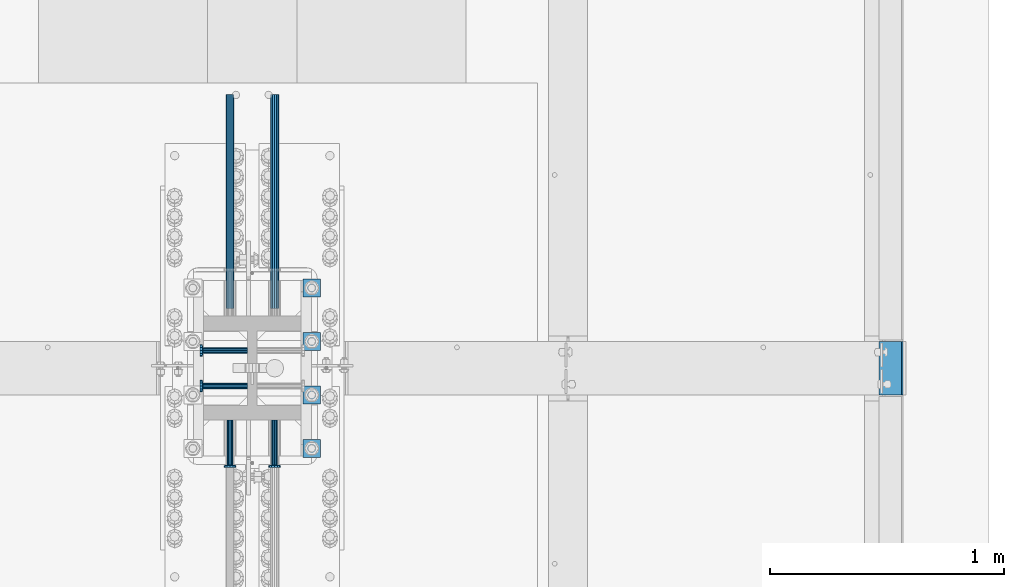
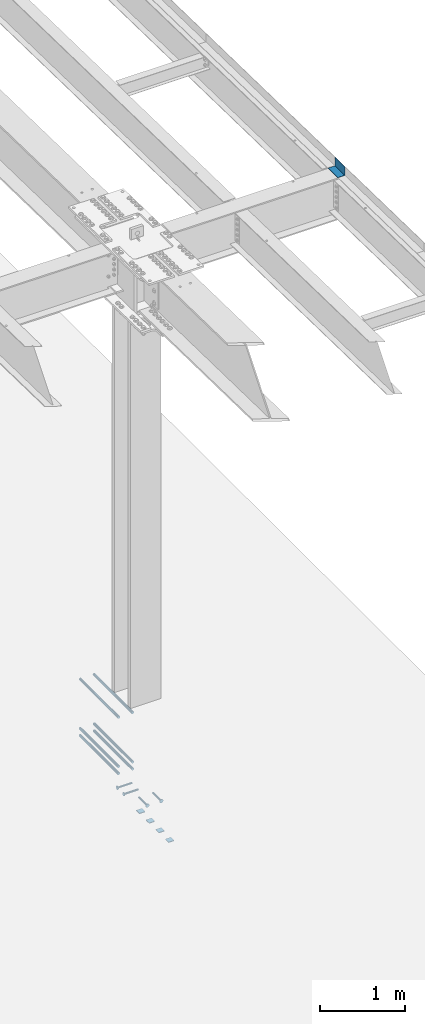
# One storey, part 1312 of 1763: 15 beams, 9 elements without a shape of their own.
"""IFC2X3 building model written with IfcOpenShell, lengths in millimetres."""

from ifc_helpers import new_model, si_unit, frame, origin_with_axes, place, context, subcontext, project, spatial, faceted_brep, material, type_object, element, aggregate, save


model = new_model("IFC2X3")

# Units and contexts
model_context = context("Model", 3, precision=1e-05, world=origin_with_axes())
body_context = subcontext(model_context, "Body", "Model", "MODEL_VIEW")
ifc_project = project(units=[si_unit("LENGTHUNIT", "METRE", prefix="MILLI"), si_unit("AREAUNIT", "SQUARE_METRE"), si_unit("VOLUMEUNIT", "CUBIC_METRE"), si_unit("MASSUNIT", "GRAM", prefix="KILO"), si_unit("TIMEUNIT", "SECOND"), si_unit("PLANEANGLEUNIT", "RADIAN"), si_unit("SOLIDANGLEUNIT", "STERADIAN"), si_unit("THERMODYNAMICTEMPERATUREUNIT", "DEGREE_CELSIUS"), si_unit("LUMINOUSINTENSITYUNIT", "LUMEN")], contexts=[model_context])

# Site, building, storey
site_placement = place(None, origin_with_axes())
site = spatial("IfcSite", under=ifc_project, at=site_placement, CompositionType="ELEMENT")
building_placement = place(site_placement, origin_with_axes())
building = spatial("IfcBuilding", under=site, at=building_placement, Name="Undefined", CompositionType="ELEMENT")
storey_placement = place(building_placement, origin_with_axes())
storey = spatial("IfcBuildingStorey", under=building, at=storey_placement, Name="Undefined", CompositionType="ELEMENT", Elevation=0.0)

# Assembly, beam
assembly_1_placement = place(storey_placement, origin_with_axes())
assembly_1 = element("IfcElementAssembly", 1, at=assembly_1_placement, inside=storey, Name="BEAM", AssemblyPlace="NOTDEFINED", PredefinedType="RIGID_FRAME")
ifc_material_1 = material(Name="STEEL/A36")
beam_type_1 = type_object("IfcBeamType", PredefinedType="NOTDEFINED")
beam_1_placement = place(assembly_1_placement, frame((-21348.1372736974, 457.200000000003, 11911.5711714953), z_axis=(0.0, -1.0, 0.0), x_axis=(1.0, 0.0, 0.0)))
beam_1 = element("IfcBeam", 2, at=beam_1_placement, type_object=beam_type_1, material=ifc_material_1, Name="BENT_PLATE", context=body_context, shape_type="Brep", body=[
    faceted_brep([(0.0, -3.17499999999927, -114.300000000003), (0.0, -3.17499999999927, 114.300000000003), (0.0, 3.17499999999927, 114.300000000003), (0.0, 3.17499999999927, -114.300000000003), (95.2499984741225, 3.17499999999927, 114.299999999999), (95.2499984741225, 3.17499999999927, -114.299999999999), (101.599998474121, -3.17499999999927, -114.299999999999), (101.599998474121, -3.17499999999927, 114.299999999999), (95.2499984741225, 123.825000000001, 114.299999999999), (95.2499984741225, 123.825000000001, -114.299999999999), (101.599998474121, 123.825000000001, 114.299999999999), (101.599998474121, 123.825000000001, -114.299999999999)], [[[0, 1, 2, 3]], [[3, 2, 4, 5]], [[1, 0, 6, 7]], [[5, 4, 8, 9]], [[4, 2, 1, 7, 10, 8]], [[7, 6, 11, 10]], [[6, 0, 3, 5, 9, 11]], [[10, 11, 9, 8]]]),
])
aggregate(assembly_1, [beam_1])

# Assembly, beams
assembly_2_placement = place(storey_placement, origin_with_axes())
assembly_2 = element("IfcElementAssembly", 3, at=assembly_2_placement, inside=storey, Name="TEMPLATE", AssemblyPlace="NOTDEFINED", PredefinedType="RIGID_FRAME")
beam_type_2 = type_object("IfcBeamType", PredefinedType="NOTDEFINED")
beam_2_placement = place(assembly_2_placement, frame((-23773.8372736984, 76.1999999999981, 3348.0375), z_axis=(1.0, 0.0, 0.0), x_axis=(0.0, 1.0, 0.0)))
beam_2 = element("IfcBeam", 4, at=beam_2_placement, type_object=beam_type_2, material=ifc_material_1, Name="WASHER PLATE", context=body_context, shape_type="Brep", body=[
    faceted_brep([(0.0, 4.76249999999709, -38.1000000000004), (0.0, 4.76249999999709, 38.1000000000004), (76.2000000000007, 4.76249999999982, 38.0999999999985), (76.2000000000007, 4.76249999999982, -38.0999999999985), (0.0, -4.76249999999709, 38.1000000000004), (76.2000000000007, -4.76249999999982, 38.0999999999985), (0.0, -4.76249999999709, -38.1000000000004), (76.2000000000007, -4.76249999999982, -38.0999999999985)], [[[0, 1, 2, 3]], [[1, 4, 5, 2]], [[4, 6, 7, 5]], [[6, 0, 3, 7]], [[5, 7, 3, 2]], [[6, 4, 1, 0]]]),
])
beam_3_placement = place(assembly_2_placement, frame((-23773.8372736984, 304.799999999998, 3348.0375), z_axis=(1.0, 0.0, 0.0), x_axis=(0.0, 1.0, 0.0)))
beam_3 = element("IfcBeam", 5, at=beam_3_placement, type_object=beam_type_2, material=ifc_material_1, Name="WASHER PLATE", context=body_context, shape_type="Brep", body=[
    faceted_brep([(0.0, 4.76249999999709, -38.1000000000004), (0.0, 4.76249999999709, 38.1000000000004), (76.2000000000007, 4.76249999999982, 38.0999999999985), (76.2000000000007, 4.76249999999982, -38.0999999999985), (0.0, -4.76249999999709, 38.1000000000004), (76.2000000000007, -4.76249999999982, 38.0999999999985), (0.0, -4.76249999999709, -38.1000000000004), (76.2000000000007, -4.76249999999982, -38.0999999999985)], [[[0, 1, 2, 3]], [[1, 4, 5, 2]], [[4, 6, 7, 5]], [[6, 0, 3, 7]], [[5, 7, 3, 2]], [[6, 4, 1, 0]]]),
])
beam_4_placement = place(assembly_2_placement, frame((-23773.8372736984, 533.399999999998, 3348.0375), z_axis=(1.0, 0.0, 0.0), x_axis=(0.0, 1.0, 0.0)))
beam_4 = element("IfcBeam", 6, at=beam_4_placement, type_object=beam_type_2, material=ifc_material_1, Name="WASHER PLATE", context=body_context, shape_type="Brep", body=[
    faceted_brep([(0.0, 4.76249999999709, -38.1000000000004), (0.0, 4.76249999999709, 38.1000000000004), (76.2000000000007, 4.76249999999982, 38.0999999999985), (76.2000000000007, 4.76249999999982, -38.0999999999985), (0.0, -4.76249999999709, 38.1000000000004), (76.2000000000007, -4.76249999999982, 38.0999999999985), (0.0, -4.76249999999709, -38.1000000000004), (76.2000000000007, -4.76249999999982, -38.0999999999985)], [[[0, 1, 2, 3]], [[1, 4, 5, 2]], [[4, 6, 7, 5]], [[6, 0, 3, 7]], [[5, 7, 3, 2]], [[6, 4, 1, 0]]]),
])
beam_5_placement = place(assembly_2_placement, frame((-23773.8372736984, 761.999999999998, 3348.0375), z_axis=(1.0, 0.0, 0.0), x_axis=(0.0, 1.0, 0.0)))
beam_5 = element("IfcBeam", 7, at=beam_5_placement, type_object=beam_type_2, material=ifc_material_1, Name="WASHER PLATE", context=body_context, shape_type="Brep", body=[
    faceted_brep([(0.0, 4.76249999999709, -38.1000000000004), (0.0, 4.76249999999709, 38.1000000000004), (76.2000000000007, 4.76249999999982, 38.0999999999985), (76.2000000000007, 4.76249999999982, -38.0999999999985), (0.0, -4.76249999999709, 38.1000000000004), (76.2000000000007, -4.76249999999982, 38.0999999999985), (0.0, -4.76249999999709, -38.1000000000004), (76.2000000000007, -4.76249999999982, -38.0999999999985)], [[[0, 1, 2, 3]], [[1, 4, 5, 2]], [[4, 6, 7, 5]], [[6, 0, 3, 7]], [[5, 7, 3, 2]], [[6, 4, 1, 0]]]),
])
aggregate(assembly_2, [beam_2, beam_3, beam_4, beam_5])

# Assembly, beam
assembly_3_placement = place(storey_placement, origin_with_axes())
assembly_3 = element("IfcElementAssembly", 8, at=assembly_3_placement, inside=storey, Name="REBAR", AssemblyPlace="NOTDEFINED", PredefinedType="RIGID_FRAME")
ifc_material_2 = material(Name="STEEL/A706-GR.80")
beam_type_3 = type_object("IfcBeamType", Name="#11 REBAR", PredefinedType="NOTDEFINED")
beam_6_placement = place(assembly_3_placement, frame((-23932.5872736985, 712.215793794025, 4165.6), z_axis=(0.0, 0.0, 1.0), x_axis=(0.0, 1.0, 0.0)))
beam_6 = element("IfcBeam", 9, at=beam_6_placement, type_object=beam_type_3, material=ifc_material_2, Name="REBAR", ObjectType="#11 REBAR", context=body_context, shape_type="Brep", body=[
    faceted_brep([(0.0, -17.9069999999992, 0.0), (0.0, -15.507916905568, -8.95349999999962), (914.400000001086, -15.507916905568, -8.95349999999962), (914.400000001086, -17.9069999999992, 0.0), (0.0, -8.95349999999962, -15.507916905568), (914.400000001086, -8.95349999999962, -15.507916905568), (0.0, 0.0, -17.9070000000002), (914.400000001086, 0.0, -17.9070000000002), (0.0, 8.95349999999962, -15.507916905568), (914.400000001086, 8.95349999999962, -15.507916905568), (0.0, 15.507916905568, -8.95349999999962), (914.400000001086, 15.507916905568, -8.95349999999962), (0.0, 17.9069999999992, 0.0), (914.400000001086, 17.9069999999992, 0.0), (0.0, 15.507916905568, 8.95349999999962), (914.400000001086, 15.507916905568, 8.95349999999962), (0.0, 8.95349999999962, 15.507916905568), (914.400000001086, 8.95349999999962, 15.507916905568), (0.0, 0.0, 17.9070000000002), (914.400000001086, 0.0, 17.9070000000002), (0.0, -8.95349999999962, 15.507916905568), (914.400000001086, -8.95349999999962, 15.507916905568), (0.0, -15.507916905568, 8.95349999999962), (914.400000001086, -15.507916905568, 8.95349999999962)], [[[0, 1, 2, 3]], [[1, 4, 5, 2]], [[4, 6, 7, 5]], [[6, 8, 9, 7]], [[8, 10, 11, 9]], [[10, 12, 13, 11]], [[12, 14, 15, 13]], [[14, 16, 17, 15]], [[16, 18, 19, 17]], [[18, 20, 21, 19]], [[20, 22, 23, 21]], [[22, 0, 3, 23]], [[5, 7, 9, 11, 13, 15, 17, 19, 21, 23, 3, 2]], [[22, 20, 18, 16, 14, 12, 10, 8, 6, 4, 1, 0]]]),
])
aggregate(assembly_3, [beam_6])

assembly_4_placement = place(storey_placement, origin_with_axes())
assembly_4 = element("IfcElementAssembly", 10, at=assembly_4_placement, inside=storey, Name="REBAR", AssemblyPlace="NOTDEFINED", PredefinedType="RIGID_FRAME")
beam_7_placement = place(assembly_4_placement, frame((-24123.0872736984, 712.215862529549, 4165.6), z_axis=(0.0, 0.0, 1.0), x_axis=(0.0, 1.0, 0.0)))
beam_7 = element("IfcBeam", 11, at=beam_7_placement, type_object=beam_type_3, material=ifc_material_2, Name="REBAR", ObjectType="#11 REBAR", context=body_context, shape_type="Brep", body=[
    faceted_brep([(0.0, -17.9069999999992, 0.0), (0.0, -15.507916905568, -8.95349999999962), (914.400000001086, -15.507916905568, -8.95349999999962), (914.400000001086, -17.9069999999992, 0.0), (0.0, -8.95349999999962, -15.507916905568), (914.400000001086, -8.95349999999962, -15.507916905568), (0.0, 0.0, -17.9070000000002), (914.400000001086, 0.0, -17.9070000000002), (0.0, 8.95349999999962, -15.507916905568), (914.400000001086, 8.95349999999962, -15.507916905568), (0.0, 15.507916905568, -8.95349999999962), (914.400000001086, 15.507916905568, -8.95349999999962), (0.0, 17.9069999999992, 0.0), (914.400000001086, 17.9069999999992, 0.0), (0.0, 15.507916905568, 8.95349999999962), (914.400000001086, 15.507916905568, 8.95349999999962), (0.0, 8.95349999999962, 15.507916905568), (914.400000001086, 8.95349999999962, 15.507916905568), (0.0, 0.0, 17.9070000000002), (914.400000001086, 0.0, 17.9070000000002), (0.0, -8.95349999999962, 15.507916905568), (914.400000001086, -8.95349999999962, 15.507916905568), (0.0, -15.507916905568, 8.95349999999962), (914.400000001086, -15.507916905568, 8.95349999999962)], [[[0, 1, 2, 3]], [[1, 4, 5, 2]], [[4, 6, 7, 5]], [[6, 8, 9, 7]], [[8, 10, 11, 9]], [[10, 12, 13, 11]], [[12, 14, 15, 13]], [[14, 16, 17, 15]], [[16, 18, 19, 17]], [[18, 20, 21, 19]], [[20, 22, 23, 21]], [[22, 0, 3, 23]], [[5, 7, 9, 11, 13, 15, 17, 19, 21, 23, 3, 2]], [[22, 20, 18, 16, 14, 12, 10, 8, 6, 4, 1, 0]]]),
])
aggregate(assembly_4, [beam_7])

assembly_5_placement = place(storey_placement, origin_with_axes())
assembly_5 = element("IfcElementAssembly", 12, at=assembly_5_placement, inside=storey, Name="REBAR", AssemblyPlace="NOTDEFINED", PredefinedType="RIGID_FRAME")
beam_8_placement = place(assembly_5_placement, frame((-23932.5872736985, 712.215793794024, 4064.0), z_axis=(0.0, 0.0, 1.0), x_axis=(0.0, 1.0, 0.0)))
beam_8 = element("IfcBeam", 13, at=beam_8_placement, type_object=beam_type_3, material=ifc_material_2, Name="REBAR", ObjectType="#11 REBAR", context=body_context, shape_type="Brep", body=[
    faceted_brep([(0.0, -17.9069999999992, 0.0), (0.0, -15.507916905568, -8.95349999999962), (914.400000001086, -15.507916905568, -8.95349999999962), (914.400000001086, -17.9069999999992, 0.0), (0.0, -8.95349999999962, -15.507916905568), (914.400000001086, -8.95349999999962, -15.507916905568), (0.0, 0.0, -17.9070000000002), (914.400000001086, 0.0, -17.9070000000002), (0.0, 8.95349999999962, -15.507916905568), (914.400000001086, 8.95349999999962, -15.507916905568), (0.0, 15.507916905568, -8.95349999999962), (914.400000001086, 15.507916905568, -8.95349999999962), (0.0, 17.9069999999992, 0.0), (914.400000001086, 17.9069999999992, 0.0), (0.0, 15.507916905568, 8.95349999999962), (914.400000001086, 15.507916905568, 8.95349999999962), (0.0, 8.95349999999962, 15.507916905568), (914.400000001086, 8.95349999999962, 15.507916905568), (0.0, 0.0, 17.9070000000002), (914.400000001086, 0.0, 17.9070000000002), (0.0, -8.95349999999962, 15.507916905568), (914.400000001086, -8.95349999999962, 15.507916905568), (0.0, -15.507916905568, 8.95349999999962), (914.400000001086, -15.507916905568, 8.95349999999962)], [[[0, 1, 2, 3]], [[1, 4, 5, 2]], [[4, 6, 7, 5]], [[6, 8, 9, 7]], [[8, 10, 11, 9]], [[10, 12, 13, 11]], [[12, 14, 15, 13]], [[14, 16, 17, 15]], [[16, 18, 19, 17]], [[18, 20, 21, 19]], [[20, 22, 23, 21]], [[22, 0, 3, 23]], [[5, 7, 9, 11, 13, 15, 17, 19, 21, 23, 3, 2]], [[22, 20, 18, 16, 14, 12, 10, 8, 6, 4, 1, 0]]]),
])
aggregate(assembly_5, [beam_8])

assembly_6_placement = place(storey_placement, origin_with_axes())
assembly_6 = element("IfcElementAssembly", 14, at=assembly_6_placement, inside=storey, Name="REBAR", AssemblyPlace="NOTDEFINED", PredefinedType="RIGID_FRAME")
beam_9_placement = place(assembly_6_placement, frame((-24123.0872736984, 712.215862529548, 4064.0), z_axis=(0.0, 0.0, 1.0), x_axis=(0.0, 1.0, 0.0)))
beam_9 = element("IfcBeam", 15, at=beam_9_placement, type_object=beam_type_3, material=ifc_material_2, Name="REBAR", ObjectType="#11 REBAR", context=body_context, shape_type="Brep", body=[
    faceted_brep([(0.0, -17.9069999999992, 0.0), (0.0, -15.507916905568, -8.95349999999962), (914.400000001086, -15.507916905568, -8.95349999999962), (914.400000001086, -17.9069999999992, 0.0), (0.0, -8.95349999999962, -15.507916905568), (914.400000001086, -8.95349999999962, -15.507916905568), (0.0, 0.0, -17.9070000000002), (914.400000001086, 0.0, -17.9070000000002), (0.0, 8.95349999999962, -15.507916905568), (914.400000001086, 8.95349999999962, -15.507916905568), (0.0, 15.507916905568, -8.95349999999962), (914.400000001086, 15.507916905568, -8.95349999999962), (0.0, 17.9069999999992, 0.0), (914.400000001086, 17.9069999999992, 0.0), (0.0, 15.507916905568, 8.95349999999962), (914.400000001086, 15.507916905568, 8.95349999999962), (0.0, 8.95349999999962, 15.507916905568), (914.400000001086, 8.95349999999962, 15.507916905568), (0.0, 0.0, 17.9070000000002), (914.400000001086, 0.0, 17.9070000000002), (0.0, -8.95349999999962, 15.507916905568), (914.400000001086, -8.95349999999962, 15.507916905568), (0.0, -15.507916905568, 8.95349999999962), (914.400000001086, -15.507916905568, 8.95349999999962)], [[[0, 1, 2, 3]], [[1, 4, 5, 2]], [[4, 6, 7, 5]], [[6, 8, 9, 7]], [[8, 10, 11, 9]], [[10, 12, 13, 11]], [[12, 14, 15, 13]], [[14, 16, 17, 15]], [[16, 18, 19, 17]], [[18, 20, 21, 19]], [[20, 22, 23, 21]], [[22, 0, 3, 23]], [[5, 7, 9, 11, 13, 15, 17, 19, 21, 23, 3, 2]], [[22, 20, 18, 16, 14, 12, 10, 8, 6, 4, 1, 0]]]),
])
aggregate(assembly_6, [beam_9])

assembly_7_placement = place(storey_placement, origin_with_axes())
assembly_7 = element("IfcElementAssembly", 16, at=assembly_7_placement, inside=storey, Name="REBAR", AssemblyPlace="NOTDEFINED", PredefinedType="RIGID_FRAME")
beam_10_placement = place(assembly_7_placement, frame((-23932.5872736985, 712.215931264474, 4876.80000000009), z_axis=(0.0, 0.0, 1.0), x_axis=(0.0, 1.0, 0.0)))
beam_10 = element("IfcBeam", 17, at=beam_10_placement, type_object=beam_type_3, material=ifc_material_2, Name="REBAR", ObjectType="#11 REBAR", context=body_context, shape_type="Brep", body=[
    faceted_brep([(0.0, -17.9069999999992, 0.0), (0.0, -15.507916905568, -8.95349999999962), (914.400000001086, -15.507916905568, -8.95349999999962), (914.400000001086, -17.9069999999992, 0.0), (0.0, -8.95349999999962, -15.507916905568), (914.400000001086, -8.95349999999962, -15.507916905568), (0.0, 0.0, -17.9070000000002), (914.400000001086, 0.0, -17.9070000000002), (0.0, 8.95349999999962, -15.507916905568), (914.400000001086, 8.95349999999962, -15.507916905568), (0.0, 15.507916905568, -8.95349999999962), (914.400000001086, 15.507916905568, -8.95349999999962), (0.0, 17.9069999999992, 0.0), (914.400000001086, 17.9069999999992, 0.0), (0.0, 15.507916905568, 8.95349999999962), (914.400000001086, 15.507916905568, 8.95349999999962), (0.0, 8.95349999999962, 15.507916905568), (914.400000001086, 8.95349999999962, 15.507916905568), (0.0, 0.0, 17.9070000000002), (914.400000001086, 0.0, 17.9070000000002), (0.0, -8.95349999999962, 15.507916905568), (914.400000001086, -8.95349999999962, 15.507916905568), (0.0, -15.507916905568, 8.95349999999962), (914.400000001086, -15.507916905568, 8.95349999999962)], [[[0, 1, 2, 3]], [[1, 4, 5, 2]], [[4, 6, 7, 5]], [[6, 8, 9, 7]], [[8, 10, 11, 9]], [[10, 12, 13, 11]], [[12, 14, 15, 13]], [[14, 16, 17, 15]], [[16, 18, 19, 17]], [[18, 20, 21, 19]], [[20, 22, 23, 21]], [[22, 0, 3, 23]], [[5, 7, 9, 11, 13, 15, 17, 19, 21, 23, 3, 2]], [[22, 20, 18, 16, 14, 12, 10, 8, 6, 4, 1, 0]]]),
])
aggregate(assembly_7, [beam_10])

assembly_8_placement = place(storey_placement, origin_with_axes())
assembly_8 = element("IfcElementAssembly", 18, at=assembly_8_placement, inside=storey, Name="REBAR", AssemblyPlace="NOTDEFINED", PredefinedType="RIGID_FRAME")
beam_11_placement = place(assembly_8_placement, frame((-24123.0872736984, 712.215999999998, 4876.80000000009), z_axis=(0.0, 0.0, 1.0), x_axis=(0.0, 1.0, 0.0)))
beam_11 = element("IfcBeam", 19, at=beam_11_placement, type_object=beam_type_3, material=ifc_material_2, Name="REBAR", ObjectType="#11 REBAR", context=body_context, shape_type="Brep", body=[
    faceted_brep([(0.0, -17.9069999999992, 0.0), (0.0, -15.507916905568, -8.95349999999962), (914.400000001086, -15.507916905568, -8.95349999999962), (914.400000001086, -17.9069999999992, 0.0), (0.0, -8.95349999999962, -15.507916905568), (914.400000001086, -8.95349999999962, -15.507916905568), (0.0, 0.0, -17.9070000000002), (914.400000001086, 0.0, -17.9070000000002), (0.0, 8.95349999999962, -15.507916905568), (914.400000001086, 8.95349999999962, -15.507916905568), (0.0, 15.507916905568, -8.95349999999962), (914.400000001086, 15.507916905568, -8.95349999999962), (0.0, 17.9069999999992, 0.0), (914.400000001086, 17.9069999999992, 0.0), (0.0, 15.507916905568, 8.95349999999962), (914.400000001086, 15.507916905568, 8.95349999999962), (0.0, 8.95349999999962, 15.507916905568), (914.400000001086, 8.95349999999962, 15.507916905568), (0.0, 0.0, 17.9070000000002), (914.400000001086, 0.0, 17.9070000000002), (0.0, -8.95349999999962, 15.507916905568), (914.400000001086, -8.95349999999962, 15.507916905568), (0.0, -15.507916905568, 8.95349999999962), (914.400000001086, -15.507916905568, 8.95349999999962)], [[[0, 1, 2, 3]], [[1, 4, 5, 2]], [[4, 6, 7, 5]], [[6, 8, 9, 7]], [[8, 10, 11, 9]], [[10, 12, 13, 11]], [[12, 14, 15, 13]], [[14, 16, 17, 15]], [[16, 18, 19, 17]], [[18, 20, 21, 19]], [[20, 22, 23, 21]], [[22, 0, 3, 23]], [[5, 7, 9, 11, 13, 15, 17, 19, 21, 23, 3, 2]], [[22, 20, 18, 16, 14, 12, 10, 8, 6, 4, 1, 0]]]),
])
aggregate(assembly_8, [beam_11])

# Assembly, beams
assembly_9_placement = place(storey_placement, origin_with_axes())
assembly_9 = element("IfcElementAssembly", 20, at=assembly_9_placement, inside=storey, Name="COLUMN", AssemblyPlace="NOTDEFINED", PredefinedType="RIGID_FRAME")
ifc_material_3 = material(Name="STEEL/A108")
beam_type_4 = type_object("IfcBeamType", PredefinedType="NOTDEFINED")
beam_12_placement = place(assembly_9_placement, frame((-24047.6810236984, 533.399999658004, 4013.2), z_axis=(0.0, -1.0, 0.0), x_axis=(-1.0, 0.0, 0.0)))
beam_12 = element("IfcBeam", 21, at=beam_12_placement, type_object=beam_type_4, material=ifc_material_3, Name="HEADED STUD ANCHOR", context=body_context, shape_type="Brep", body=[
    faceted_brep([(0.0, -12.6999999999971, -1.81898940354586e-12), (3.63797880709171e-12, -11.0, -6.34999990463257), (191.00799999576, -11.0, -6.34999990454889), (191.007999995752, -12.6999998092651, 8.36735125631094e-11), (7.27595761418343e-12, -6.34999990463257, -11.0), (191.00799999576, -6.34999990463257, -10.9999999999163), (3.63797880709171e-12, 0.0, -12.6999998092651), (191.00799999576, 0.0, -12.6999998091815), (7.27595761418343e-12, 6.34999990463257, -11.0), (191.00799999576, 6.34999990463257, -10.9999999999163), (3.63797880709171e-12, 11.0, -6.34999990463257), (191.00799999576, 11.0, -6.34999990454889), (0.0, 12.6999999999971, -1.81898940354586e-12), (191.007999995752, 12.6999998092651, 8.36735125631094e-11), (0.0, 11.0, 6.34999990463257), (191.007999995752, 11.0, 6.34999990471624), (-3.63797880709171e-12, 6.34999990463257, 11.0), (191.007999995749, 6.34999990463257, 11.0000000000837), (-3.63797880709171e-12, 0.0, 12.6999998092651), (191.007999995749, 0.0, 12.6999998093488), (-3.63797880709171e-12, -6.34999990463257, 11.0), (191.007999995749, -6.34999990463257, 11.0000000000837), (0.0, -11.0, 6.34999990463257), (191.007999995752, -11.0, 6.34999990471624), (193.039999995715, -22.0, -12.6999998091796), (193.039999995708, -25.3999996185303, 8.54925019666553e-11), (193.039999995719, -12.6999998092651, -21.9999999999145), (193.039999995719, 0.0, -25.3999996184448), (193.039999995719, 12.6999998092651, -21.9999999999145), (193.039999995715, 22.0, -12.6999998091796), (193.039999995708, 25.3999996185303, 8.54925019666553e-11), (193.039999995704, 22.0, 12.6999998093506), (193.039999995701, 12.6999998092651, 22.0000000000855), (193.039999995697, 0.0, 25.3999996186158), (193.039999995701, -12.6999998092651, 22.0000000000855), (193.039999995704, -22.0, 12.6999998093506), (203.199999995486, -22.0, -12.6999998091742), (203.199999995482, -25.3999996185303, 9.09494701772928e-11), (203.199999995493, -12.6999998092651, -21.9999999999091), (203.199999995493, 0.0, -25.3999996184393), (203.199999995493, 12.6999998092651, -21.9999999999091), (203.199999995486, 22.0, -12.6999998091742), (203.199999995482, 25.3999996185303, 9.09494701772928e-11), (203.199999995479, 22.0, 12.6999998093561), (203.199999995475, 12.6999998092651, 22.0000000000909), (203.199999995471, 0.0, 25.3999996186212), (203.199999995475, -12.6999998092651, 22.0000000000909), (203.199999995479, -22.0, 12.6999998093561)], [[[0, 1, 2, 3]], [[1, 4, 5, 2]], [[4, 6, 7, 5]], [[6, 8, 9, 7]], [[8, 10, 11, 9]], [[10, 12, 13, 11]], [[12, 14, 15, 13]], [[14, 16, 17, 15]], [[16, 18, 19, 17]], [[18, 20, 21, 19]], [[20, 22, 23, 21]], [[22, 0, 3, 23]], [[22, 20, 18, 16, 14, 12, 10, 8, 6, 4, 1, 0]], [[3, 2, 24, 25]], [[2, 5, 26, 24]], [[5, 7, 27, 26]], [[7, 9, 28, 27]], [[9, 11, 29, 28]], [[11, 13, 30, 29]], [[13, 15, 31, 30]], [[15, 17, 32, 31]], [[17, 19, 33, 32]], [[19, 21, 34, 33]], [[21, 23, 35, 34]], [[23, 3, 25, 35]], [[25, 24, 36, 37]], [[24, 26, 38, 36]], [[26, 27, 39, 38]], [[27, 28, 40, 39]], [[28, 29, 41, 40]], [[29, 30, 42, 41]], [[30, 31, 43, 42]], [[31, 32, 44, 43]], [[32, 33, 45, 44]], [[33, 34, 46, 45]], [[34, 35, 47, 46]], [[35, 25, 37, 47]], [[38, 39, 40, 41, 42, 43, 44, 45, 46, 47, 37, 36]]]),
])
beam_13_placement = place(assembly_9_placement, frame((-24047.6810235841, 380.999999658919, 4013.2), z_axis=(0.0, -1.0, 0.0), x_axis=(-1.0, 0.0, 0.0)))
beam_13 = element("IfcBeam", 22, at=beam_13_placement, type_object=beam_type_4, material=ifc_material_3, Name="HEADED STUD ANCHOR", context=body_context, shape_type="Brep", body=[
    faceted_brep([(0.0, -12.6999999999971, -1.81898940354586e-12), (3.63797880709171e-12, -11.0, -6.34999990463257), (191.00799999576, -11.0, -6.34999990454889), (191.007999995752, -12.6999998092651, 8.36735125631094e-11), (7.27595761418343e-12, -6.34999990463257, -11.0), (191.00799999576, -6.34999990463257, -10.9999999999163), (3.63797880709171e-12, 0.0, -12.6999998092651), (191.00799999576, 0.0, -12.6999998091815), (7.27595761418343e-12, 6.34999990463257, -11.0), (191.00799999576, 6.34999990463257, -10.9999999999163), (3.63797880709171e-12, 11.0, -6.34999990463257), (191.00799999576, 11.0, -6.34999990454889), (0.0, 12.6999999999971, -1.81898940354586e-12), (191.007999995752, 12.6999998092651, 8.36735125631094e-11), (0.0, 11.0, 6.34999990463257), (191.007999995752, 11.0, 6.34999990471624), (-3.63797880709171e-12, 6.34999990463257, 11.0), (191.007999995749, 6.34999990463257, 11.0000000000837), (-3.63797880709171e-12, 0.0, 12.6999998092651), (191.007999995749, 0.0, 12.6999998093488), (-3.63797880709171e-12, -6.34999990463257, 11.0), (191.007999995749, -6.34999990463257, 11.0000000000837), (0.0, -11.0, 6.34999990463257), (191.007999995752, -11.0, 6.34999990471624), (193.039999995715, -22.0, -12.6999998091796), (193.039999995708, -25.3999996185303, 8.54925019666553e-11), (193.039999995719, -12.6999998092651, -21.9999999999145), (193.039999995719, 0.0, -25.3999996184448), (193.039999995719, 12.6999998092651, -21.9999999999145), (193.039999995715, 22.0, -12.6999998091796), (193.039999995708, 25.3999996185303, 8.54925019666553e-11), (193.039999995704, 22.0, 12.6999998093506), (193.039999995701, 12.6999998092651, 22.0000000000855), (193.039999995697, 0.0, 25.3999996186158), (193.039999995701, -12.6999998092651, 22.0000000000855), (193.039999995704, -22.0, 12.6999998093506), (203.199999995486, -22.0, -12.6999998091742), (203.199999995482, -25.3999996185303, 9.09494701772928e-11), (203.199999995493, -12.6999998092651, -21.9999999999091), (203.199999995493, 0.0, -25.3999996184393), (203.199999995493, 12.6999998092651, -21.9999999999091), (203.199999995486, 22.0, -12.6999998091742), (203.199999995482, 25.3999996185303, 9.09494701772928e-11), (203.199999995479, 22.0, 12.6999998093561), (203.199999995475, 12.6999998092651, 22.0000000000909), (203.199999995471, 0.0, 25.3999996186212), (203.199999995475, -12.6999998092651, 22.0000000000909), (203.199999995479, -22.0, 12.6999998093561)], [[[0, 1, 2, 3]], [[1, 4, 5, 2]], [[4, 6, 7, 5]], [[6, 8, 9, 7]], [[8, 10, 11, 9]], [[10, 12, 13, 11]], [[12, 14, 15, 13]], [[14, 16, 17, 15]], [[16, 18, 19, 17]], [[18, 20, 21, 19]], [[20, 22, 23, 21]], [[22, 0, 3, 23]], [[22, 20, 18, 16, 14, 12, 10, 8, 6, 4, 1, 0]], [[3, 2, 24, 25]], [[2, 5, 26, 24]], [[5, 7, 27, 26]], [[7, 9, 28, 27]], [[9, 11, 29, 28]], [[11, 13, 30, 29]], [[13, 15, 31, 30]], [[15, 17, 32, 31]], [[17, 19, 33, 32]], [[19, 21, 34, 33]], [[21, 23, 35, 34]], [[23, 3, 25, 35]], [[25, 24, 36, 37]], [[24, 26, 38, 36]], [[26, 27, 39, 38]], [[27, 28, 40, 39]], [[28, 29, 41, 40]], [[29, 30, 42, 41]], [[30, 31, 43, 42]], [[31, 32, 44, 43]], [[32, 33, 45, 44]], [[33, 34, 46, 45]], [[34, 35, 47, 46]], [[35, 25, 37, 47]], [[38, 39, 40, 41, 42, 43, 44, 45, 46, 47, 37, 36]]]),
])
beam_14_placement = place(assembly_9_placement, frame((-24123.0872736977, 234.950133352678, 4013.2), z_axis=(1.0, 0.0, 0.0), x_axis=(0.0, -1.0, 0.0)))
beam_14 = element("IfcBeam", 23, at=beam_14_placement, type_object=beam_type_4, material=ifc_material_3, Name="HEADED STUD ANCHOR", context=body_context, shape_type="Brep", body=[
    faceted_brep([(0.0, -12.6999999999971, -1.81898940354586e-12), (3.63797880709171e-12, -11.0, -6.34999990463257), (191.00799999576, -11.0, -6.34999990454889), (191.007999995752, -12.6999998092651, 8.36735125631094e-11), (7.27595761418343e-12, -6.34999990463257, -11.0), (191.00799999576, -6.34999990463257, -10.9999999999163), (3.63797880709171e-12, 0.0, -12.6999998092651), (191.00799999576, 0.0, -12.6999998091815), (7.27595761418343e-12, 6.34999990463257, -11.0), (191.00799999576, 6.34999990463257, -10.9999999999163), (3.63797880709171e-12, 11.0, -6.34999990463257), (191.00799999576, 11.0, -6.34999990454889), (0.0, 12.6999999999971, -1.81898940354586e-12), (191.007999995752, 12.6999998092651, 8.36735125631094e-11), (0.0, 11.0, 6.34999990463257), (191.007999995752, 11.0, 6.34999990471624), (-3.63797880709171e-12, 6.34999990463257, 11.0), (191.007999995749, 6.34999990463257, 11.0000000000837), (-3.63797880709171e-12, 0.0, 12.6999998092651), (191.007999995749, 0.0, 12.6999998093488), (-3.63797880709171e-12, -6.34999990463257, 11.0), (191.007999995749, -6.34999990463257, 11.0000000000837), (0.0, -11.0, 6.34999990463257), (191.007999995752, -11.0, 6.34999990471624), (193.039999995715, -22.0, -12.6999998091796), (193.039999995708, -25.3999996185303, 8.54925019666553e-11), (193.039999995719, -12.6999998092651, -21.9999999999145), (193.039999995719, 0.0, -25.3999996184448), (193.039999995719, 12.6999998092651, -21.9999999999145), (193.039999995715, 22.0, -12.6999998091796), (193.039999995708, 25.3999996185303, 8.54925019666553e-11), (193.039999995704, 22.0, 12.6999998093506), (193.039999995701, 12.6999998092651, 22.0000000000855), (193.039999995697, 0.0, 25.3999996186158), (193.039999995701, -12.6999998092651, 22.0000000000855), (193.039999995704, -22.0, 12.6999998093506), (203.199999995486, -22.0, -12.6999998091742), (203.199999995482, -25.3999996185303, 9.09494701772928e-11), (203.199999995493, -12.6999998092651, -21.9999999999091), (203.199999995493, 0.0, -25.3999996184393), (203.199999995493, 12.6999998092651, -21.9999999999091), (203.199999995486, 22.0, -12.6999998091742), (203.199999995482, 25.3999996185303, 9.09494701772928e-11), (203.199999995479, 22.0, 12.6999998093561), (203.199999995475, 12.6999998092651, 22.0000000000909), (203.199999995471, 0.0, 25.3999996186212), (203.199999995475, -12.6999998092651, 22.0000000000909), (203.199999995479, -22.0, 12.6999998093561)], [[[0, 1, 2, 3]], [[1, 4, 5, 2]], [[4, 6, 7, 5]], [[6, 8, 9, 7]], [[8, 10, 11, 9]], [[10, 12, 13, 11]], [[12, 14, 15, 13]], [[14, 16, 17, 15]], [[16, 18, 19, 17]], [[18, 20, 21, 19]], [[20, 22, 23, 21]], [[22, 0, 3, 23]], [[22, 20, 18, 16, 14, 12, 10, 8, 6, 4, 1, 0]], [[3, 2, 24, 25]], [[2, 5, 26, 24]], [[5, 7, 27, 26]], [[7, 9, 28, 27]], [[9, 11, 29, 28]], [[11, 13, 30, 29]], [[13, 15, 31, 30]], [[15, 17, 32, 31]], [[17, 19, 33, 32]], [[19, 21, 34, 33]], [[21, 23, 35, 34]], [[23, 3, 25, 35]], [[25, 24, 36, 37]], [[24, 26, 38, 36]], [[26, 27, 39, 38]], [[27, 28, 40, 39]], [[28, 29, 41, 40]], [[29, 30, 42, 41]], [[30, 31, 43, 42]], [[31, 32, 44, 43]], [[32, 33, 45, 44]], [[33, 34, 46, 45]], [[34, 35, 47, 46]], [[35, 25, 37, 47]], [[38, 39, 40, 41, 42, 43, 44, 45, 46, 47, 37, 36]]]),
])
beam_15_placement = place(assembly_9_placement, frame((-23932.5872736984, 234.950064692176, 4013.2), z_axis=(1.0, 0.0, 0.0), x_axis=(0.0, -1.0, 0.0)))
beam_15 = element("IfcBeam", 24, at=beam_15_placement, type_object=beam_type_4, material=ifc_material_3, Name="HEADED STUD ANCHOR", context=body_context, shape_type="Brep", body=[
    faceted_brep([(0.0, -12.6999999999971, -1.81898940354586e-12), (3.63797880709171e-12, -11.0, -6.34999990463257), (191.00799999576, -11.0, -6.34999990454889), (191.007999995752, -12.6999998092651, 8.36735125631094e-11), (7.27595761418343e-12, -6.34999990463257, -11.0), (191.00799999576, -6.34999990463257, -10.9999999999163), (3.63797880709171e-12, 0.0, -12.6999998092651), (191.00799999576, 0.0, -12.6999998091815), (7.27595761418343e-12, 6.34999990463257, -11.0), (191.00799999576, 6.34999990463257, -10.9999999999163), (3.63797880709171e-12, 11.0, -6.34999990463257), (191.00799999576, 11.0, -6.34999990454889), (0.0, 12.6999999999971, -1.81898940354586e-12), (191.007999995752, 12.6999998092651, 8.36735125631094e-11), (0.0, 11.0, 6.34999990463257), (191.007999995752, 11.0, 6.34999990471624), (-3.63797880709171e-12, 6.34999990463257, 11.0), (191.007999995749, 6.34999990463257, 11.0000000000837), (-3.63797880709171e-12, 0.0, 12.6999998092651), (191.007999995749, 0.0, 12.6999998093488), (-3.63797880709171e-12, -6.34999990463257, 11.0), (191.007999995749, -6.34999990463257, 11.0000000000837), (0.0, -11.0, 6.34999990463257), (191.007999995752, -11.0, 6.34999990471624), (193.039999995715, -22.0, -12.6999998091796), (193.039999995708, -25.3999996185303, 8.54925019666553e-11), (193.039999995719, -12.6999998092651, -21.9999999999145), (193.039999995719, 0.0, -25.3999996184448), (193.039999995719, 12.6999998092651, -21.9999999999145), (193.039999995715, 22.0, -12.6999998091796), (193.039999995708, 25.3999996185303, 8.54925019666553e-11), (193.039999995704, 22.0, 12.6999998093506), (193.039999995701, 12.6999998092651, 22.0000000000855), (193.039999995697, 0.0, 25.3999996186158), (193.039999995701, -12.6999998092651, 22.0000000000855), (193.039999995704, -22.0, 12.6999998093506), (203.199999995486, -22.0, -12.6999998091742), (203.199999995482, -25.3999996185303, 9.09494701772928e-11), (203.199999995493, -12.6999998092651, -21.9999999999091), (203.199999995493, 0.0, -25.3999996184393), (203.199999995493, 12.6999998092651, -21.9999999999091), (203.199999995486, 22.0, -12.6999998091742), (203.199999995482, 25.3999996185303, 9.09494701772928e-11), (203.199999995479, 22.0, 12.6999998093561), (203.199999995475, 12.6999998092651, 22.0000000000909), (203.199999995471, 0.0, 25.3999996186212), (203.199999995475, -12.6999998092651, 22.0000000000909), (203.199999995479, -22.0, 12.6999998093561)], [[[0, 1, 2, 3]], [[1, 4, 5, 2]], [[4, 6, 7, 5]], [[6, 8, 9, 7]], [[8, 10, 11, 9]], [[10, 12, 13, 11]], [[12, 14, 15, 13]], [[14, 16, 17, 15]], [[16, 18, 19, 17]], [[18, 20, 21, 19]], [[20, 22, 23, 21]], [[22, 0, 3, 23]], [[22, 20, 18, 16, 14, 12, 10, 8, 6, 4, 1, 0]], [[3, 2, 24, 25]], [[2, 5, 26, 24]], [[5, 7, 27, 26]], [[7, 9, 28, 27]], [[9, 11, 29, 28]], [[11, 13, 30, 29]], [[13, 15, 31, 30]], [[15, 17, 32, 31]], [[17, 19, 33, 32]], [[19, 21, 34, 33]], [[21, 23, 35, 34]], [[23, 3, 25, 35]], [[25, 24, 36, 37]], [[24, 26, 38, 36]], [[26, 27, 39, 38]], [[27, 28, 40, 39]], [[28, 29, 41, 40]], [[29, 30, 42, 41]], [[30, 31, 43, 42]], [[31, 32, 44, 43]], [[32, 33, 45, 44]], [[33, 34, 46, 45]], [[34, 35, 47, 46]], [[35, 25, 37, 47]], [[38, 39, 40, 41, 42, 43, 44, 45, 46, 47, 37, 36]]]),
])
aggregate(assembly_9, [beam_12, beam_13, beam_14, beam_15])

save(model, "model.ifc")
